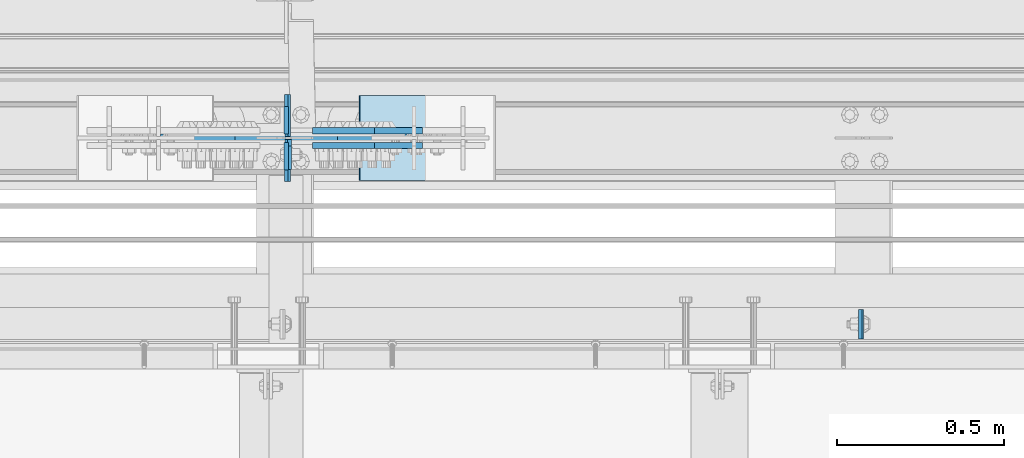
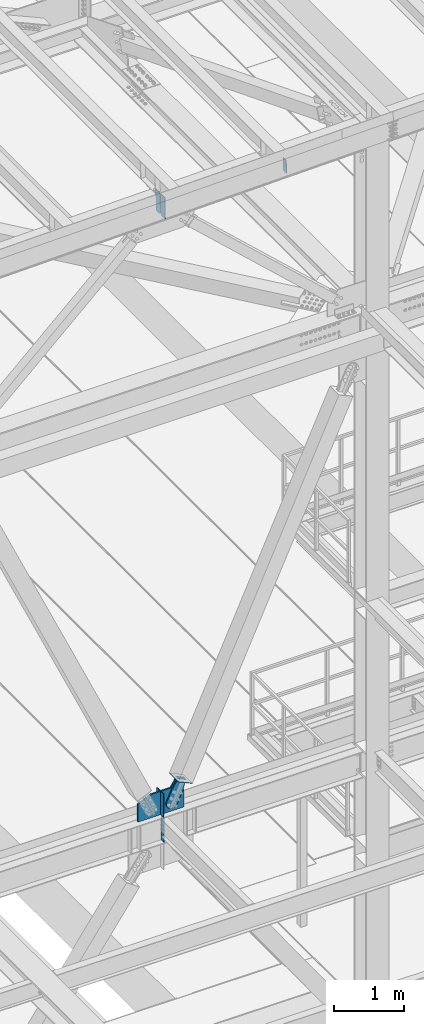
# One storey, part 3130 of 3843: 10 plates, 6 elements without a shape of their own.
"""IFC2X3 building model written with IfcOpenShell, lengths in millimetres."""

import ifcopenshell
import ifcopenshell.guid

model = None  # the IFC model being written
_history = None  # IfcOwnerHistory: only IFC2X3 demands one
_inside = {}  # id of a spatial element -> (the spatial element, [elements in it])
_under = {}  # id of a project, library or spatial element -> (it, [spatial elements below it])
_declared = {}  # id of a project -> (the project, [libraries it declares])
_typed = {}  # id of a type object -> (the type object, [elements of that type])
_made_of = {}  # id of a material, layer set ... -> (it, [elements and type objects made of it])


def new_model(schema):
    """Start an empty IFC model of exactly this schema.

    Asked for "IFC4X3", IfcOpenShell would pick the latest addendum, in which some entities
    have other attributes; the version numbers below select the first issue.
    IFC2X3 requires an IfcOwnerHistory on every rooted entity: one is made here for all.
    """
    global model, _history
    if schema == "IFC4X3":
        model = ifcopenshell.file(schema_version=(4, 3, 0, 0))
    else:
        model = ifcopenshell.file(schema=schema)
    _inside.clear()
    _under.clear()
    _declared.clear()
    _typed.clear()
    _made_of.clear()
    _history = None
    if model.schema == "IFC2X3":
        org = make("IfcOrganization", Name="unknown")
        user = make(
            "IfcPersonAndOrganization",
            ThePerson=make("IfcPerson", FamilyName="unknown"),
            TheOrganization=org,
        )
        app = make(
            "IfcApplication",
            ApplicationDeveloper=org,
            Version="unknown",
            ApplicationFullName="unknown",
            ApplicationIdentifier="unknown",
        )
        _history = make(
            "IfcOwnerHistory",
            OwningUser=user,
            OwningApplication=app,
            ChangeAction="ADDED",
            CreationDate=0,
        )
    return model


def make(cls, **values):
    """One entity of the class cls with the attributes given. An attribute that is None is left unset."""
    return model.create_entity(
        cls, **{name: value for name, value in values.items() if value is not None}
    )


def rooted(cls, **values):
    """An entity with a GlobalId (a new one), such as an element, a storey or a relation."""
    return make(cls, GlobalId=ifcopenshell.guid.new(), OwnerHistory=_history, **values)


def si_unit(unit_type, name, prefix=None):
    """IfcSIUnit, for example si_unit("LENGTHUNIT", "METRE", prefix="MILLI")."""
    return make("IfcSIUnit", UnitType=unit_type, Prefix=prefix, Name=name)


def assignment(units):
    """IfcUnitAssignment: the units of a project."""
    return None if units is None else make("IfcUnitAssignment", Units=units)


def point(xyz):
    """IfcCartesianPoint."""
    return None if xyz is None else make("IfcCartesianPoint", Coordinates=xyz)


def direction(xyz):
    """IfcDirection."""
    return None if xyz is None else make("IfcDirection", DirectionRatios=xyz)


def frame(location, z_axis=None, x_axis=None):
    """IfcAxis2Placement3D, a coordinate frame: its origin and axes. An axis left out is left unset."""
    return make(
        "IfcAxis2Placement3D",
        Location=point(location),
        Axis=direction(z_axis),
        RefDirection=direction(x_axis),
    )


def origin_with_axes():
    """The frame at (0, 0, 0) with the z axis (0, 0, 1) and the x axis (1, 0, 0) written out."""
    return frame((0.0, 0.0, 0.0), z_axis=(0.0, 0.0, 1.0), x_axis=(1.0, 0.0, 0.0))


def place(relative_to, where):
    """IfcLocalPlacement: puts the frame where relative to a parent placement (None: the world)."""
    return make(
        "IfcLocalPlacement", PlacementRelTo=relative_to, RelativePlacement=where
    )


def context(
    kind, dimensions, precision=None, world=None, true_north=None, identifier=None
):
    """IfcGeometricRepresentationContext, for example the 3D "Model" context."""
    return make(
        "IfcGeometricRepresentationContext",
        ContextIdentifier=identifier,
        ContextType=kind,
        CoordinateSpaceDimension=dimensions,
        Precision=precision,
        WorldCoordinateSystem=world,
        TrueNorth=true_north,
    )


def subcontext(parent, identifier, kind, view, scale=None):
    """IfcGeometricRepresentationSubContext, for example "Body" below "Model"."""
    return make(
        "IfcGeometricRepresentationSubContext",
        ContextIdentifier=identifier,
        ContextType=kind,
        ParentContext=parent,
        TargetScale=scale,
        TargetView=view,
    )


def project(units=None, contexts=None):
    """IfcProject with its units and contexts."""
    return rooted(
        "IfcProject",
        Name="project",
        RepresentationContexts=contexts,
        UnitsInContext=assignment(units),
    )


def spatial(cls, under=None, at=None, **own):
    """A site, building, storey or space (cls), placed at a placement, below another one or the project."""
    s = rooted(cls, ObjectPlacement=at, **own)
    if under is not None:
        _under.setdefault(under.id(), (under, []))[1].append(s)
    return s


def faces_of(points, faces, orient=None, outer=None):
    """IfcFace entities. A face is a list of loops; a loop is a list of indices into points, from 0.

    orient and outer hold one flag for each loop. By default every Orientation is true, the
    first loop of a face is its IfcFaceOuterBound and the others are IfcFaceBound.
    """
    made = []
    for i, loops in enumerate(faces):
        bounds = []
        for j, loop in enumerate(loops):
            is_outer = j == 0 if outer is None else outer[i][j]
            bounds.append(
                make(
                    "IfcFaceOuterBound" if is_outer else "IfcFaceBound",
                    Bound=make("IfcPolyLoop", Polygon=[points[k] for k in loop]),
                    Orientation=True if orient is None else orient[i][j],
                )
            )
        made.append(make("IfcFace", Bounds=bounds))
    return made


def faceted_brep(points, faces, orient=None, outer=None, voids=None):
    """IfcFacetedBrep: a solid bounded by flat faces; with voids (closed shells), ...WithVoids."""
    shared = [point(p) for p in points]
    hull = make("IfcClosedShell", CfsFaces=faces_of(shared, faces, orient, outer))
    if voids is None:
        return make("IfcFacetedBrep", Outer=hull)
    return make(
        "IfcFacetedBrepWithVoids",
        Outer=hull,
        Voids=[
            make(cls, CfsFaces=faces_of(shared, fs, o, b)) for cls, fs, o, b in voids
        ],
    )


def shape(context_of_items, identifier, shape_type, items):
    """IfcShapeRepresentation: the items that make up one representation, for example the "Body"."""
    return make(
        "IfcShapeRepresentation",
        ContextOfItems=context_of_items,
        RepresentationIdentifier=identifier,
        RepresentationType=shape_type,
        Items=items,
    )


def material(Name=None, Category=None):
    """IfcMaterial."""
    return make("IfcMaterial", Name=Name, Category=Category)


def made_of(thing, what):
    """Note that an element or type object is made of a material, layer set ...; save() writes the relation."""
    if what is not None:
        _made_of.setdefault(what.id(), (what, []))[1].append(thing)
    return thing


def type_object(cls, material=None, **own):
    """A type object (cls), such as IfcWallType, which elements share."""
    return made_of(rooted(cls, **own), material)


def element(
    cls,
    number,
    at=None,
    inside=None,
    cuts=None,
    type_object=None,
    material=None,
    context=None,
    identifier="Body",
    shape_type=None,
    held_by="IfcProductDefinitionShape",
    body=None,
    shapes=None,
    **own,
):
    """One element of the class cls, such as IfcWall. Its Tag is "e" and its number.

    at: its placement. inside: the storey or other place that contains it. cuts: it is an
    opening in that element (IfcRelVoidsElement). A single representation is given by context,
    identifier, shape_type and body (its items); several are given by shapes. held_by: the class
    of the entity that holds the representations. save() writes the other relations.
    """
    e = rooted(cls, Tag="e%d" % number, ObjectPlacement=at, **own)
    if body is not None:
        shapes = [shape(context, identifier, shape_type, body)]
    if shapes is not None:
        e.Representation = make(held_by, Representations=shapes)
    if inside is not None:
        _inside.setdefault(inside.id(), (inside, []))[1].append(e)
    if cuts is not None:
        rooted(
            "IfcRelVoidsElement", RelatingBuildingElement=cuts, RelatedOpeningElement=e
        )
    if type_object is not None:
        _typed.setdefault(type_object.id(), (type_object, []))[1].append(e)
    return made_of(e, material)


def aggregate(whole, parts):
    """IfcRelAggregates: a whole, such as a stair, and the parts it consists of."""
    return rooted("IfcRelAggregates", RelatingObject=whole, RelatedObjects=parts)


def save(model, path):
    """Write the relations noted so far, then the file.

    IfcRelAggregates (storeys below a building ...), IfcRelContainedInSpatialStructure (elements
    in a storey), IfcRelDefinesByType, IfcRelAssociatesMaterial and IfcRelDeclares: one each for
    every whole, place, type object, material and project.
    """
    for whole, parts in _under.values():
        aggregate(whole, parts)
    for where, things in _inside.values():
        rooted(
            "IfcRelContainedInSpatialStructure",
            RelatedElements=things,
            RelatingStructure=where,
        )
    for kind, things in _typed.values():
        rooted("IfcRelDefinesByType", RelatedObjects=things, RelatingType=kind)
    for what, things in _made_of.values():
        rooted("IfcRelAssociatesMaterial", RelatedObjects=things, RelatingMaterial=what)
    for by, libraries in _declared.values():
        rooted("IfcRelDeclares", RelatingContext=by, RelatedDefinitions=libraries)
    model.write(path)


model = new_model("IFC2X3")

# Units and contexts
model_context = context("Model", 3, precision=1e-05, world=origin_with_axes())
body_context = subcontext(model_context, "Body", "Model", "MODEL_VIEW")
ifc_project = project(units=[si_unit("LENGTHUNIT", "METRE", prefix="MILLI"), si_unit("AREAUNIT", "SQUARE_METRE"), si_unit("VOLUMEUNIT", "CUBIC_METRE"), si_unit("MASSUNIT", "GRAM", prefix="KILO"), si_unit("TIMEUNIT", "SECOND"), si_unit("PLANEANGLEUNIT", "RADIAN"), si_unit("SOLIDANGLEUNIT", "STERADIAN"), si_unit("THERMODYNAMICTEMPERATUREUNIT", "DEGREE_CELSIUS"), si_unit("LUMINOUSINTENSITYUNIT", "LUMEN")], contexts=[model_context])

# Site, building, storey
site_placement = place(None, origin_with_axes())
site = spatial("IfcSite", under=ifc_project, at=site_placement, CompositionType="ELEMENT")
building_placement = place(site_placement, origin_with_axes())
building = spatial("IfcBuilding", under=site, at=building_placement, Name="Undefined", CompositionType="ELEMENT")
storey_placement = place(building_placement, origin_with_axes())
storey = spatial("IfcBuildingStorey", under=building, at=storey_placement, Name="Undefined", CompositionType="ELEMENT", Elevation=0.0)

# Assembly, plate
assembly_1_placement = place(storey_placement, origin_with_axes())
assembly_1 = element("IfcElementAssembly", 1, at=assembly_1_placement, inside=storey, Name="BEAM", AssemblyPlace="NOTDEFINED", PredefinedType="RIGID_FRAME")
ifc_material_1 = material(Name="STEEL/A572-50")
plate_type_1 = type_object("IfcPlateType", PredefinedType="NOTDEFINED")
plate_1_placement = place(assembly_1_placement, frame((47249.338147201, 25014.2375588453, 45917.3307219245), z_axis=(1.23360001962283e-05, 0.999999999923877, 2.60990629612933e-07), x_axis=(0.0211520550054438, 0.0, -0.999776270257025)))
plate_1 = element("IfcPlate", 2, at=plate_1_placement, type_object=plate_type_1, material=ifc_material_1, Name="PLATE", context=body_context, shape_type="Brep", body=[
    faceted_brep([(0.0, -4.76249999999709, 0.0), (0.0, -4.76249999999709, 88.9000015258789), (0.0, 4.76249999999709, 88.9000015258789), (0.0, 4.76249999999709, 0.0), (228.600006102781, -4.7625000004191, 88.9000015257589), (228.600006102781, 4.76249999954598, 88.9000015257443), (228.600006103079, -4.7625000004482, 7.27595761418343e-12), (228.600006103079, 4.76249999954598, -7.27595761418343e-12)], [[[0, 1, 2, 3]], [[1, 4, 5, 2]], [[4, 6, 7, 5]], [[6, 0, 3, 7]], [[5, 7, 3, 2]], [[6, 4, 1, 0]]]),
])
aggregate(assembly_1, [plate_1])

# Assembly, plates
assembly_2_placement = place(storey_placement, origin_with_axes())
assembly_2 = element("IfcElementAssembly", 3, at=assembly_2_placement, inside=storey, Name="BEAM", AssemblyPlace="NOTDEFINED", PredefinedType="RIGID_FRAME")
plate_type_2 = type_object("IfcPlateType", PredefinedType="NOTDEFINED")
plate_2_placement = place(assembly_2_placement, frame((45537.8947387129, 25485.725, 45211.0164858346), z_axis=(-0.0211520980073474, 0.0, 0.999776269347241), x_axis=(0.0, 1.0, 0.0)))
plate_2 = element("IfcPlate", 4, at=plate_2_placement, type_object=plate_type_2, material=ifc_material_1, Name="STIFFENER", context=body_context, shape_type="Brep", body=[
    faceted_brep([(0.0, -4.76249999999709, 0.0), (0.0, -4.76249999999709, 377.824999997538), (0.0, 4.76249999999709, 377.824999997538), (0.0, 4.76249999999709, 0.0), (103.187499618536, -4.76249999999709, 377.824999997538), (103.187499618536, 4.76249999999709, 377.824999997538), (125.412500000006, -4.76249999999709, 355.599999616068), (125.412500000006, 4.76249999999709, 355.599999616068), (125.412500000006, -4.76249999999709, 22.2250003814697), (125.412500000006, 4.76249999999709, 22.2250003814697), (103.187499618536, -4.76249999999709, 0.0), (103.187499618536, 4.76249999999709, 0.0)], [[[0, 1, 2, 3]], [[1, 4, 5, 2]], [[4, 6, 7, 5]], [[6, 8, 9, 7]], [[8, 10, 11, 9]], [[10, 0, 3, 11]], [[5, 7, 9, 11, 3, 2]], [[10, 8, 6, 4, 1, 0]]]),
])
plate_3_placement = place(assembly_2_placement, frame((45537.8947387129, 25620.6625, 45211.0164858346), z_axis=(-0.0211520980073474, 0.0, 0.999776269347241), x_axis=(0.0, 1.0, 0.0)))
plate_3 = element("IfcPlate", 5, at=plate_3_placement, type_object=plate_type_2, material=ifc_material_1, Name="STIFFENER", context=body_context, shape_type="Brep", body=[
    faceted_brep([(0.0, -4.76249999999709, 22.2250003814697), (0.0, -4.76249999999709, 355.599999616068), (0.0, 4.76249999999709, 355.599999616068), (0.0, 4.76249999999709, 22.2250003814697), (22.2250003814697, -4.76249999999709, 377.824999997538), (22.2250003814697, 4.76249999999709, 377.824999997538), (125.412500000006, -4.76249999999709, 377.824999997538), (125.412500000006, 4.76249999999709, 377.824999997538), (125.412500000006, -4.76249999999709, 0.0), (125.412500000006, 4.76249999999709, 0.0), (22.2250003814697, -4.76249999999709, 0.0), (22.2250003814697, 4.76249999999709, 0.0)], [[[0, 1, 2, 3]], [[1, 4, 5, 2]], [[4, 6, 7, 5]], [[6, 8, 9, 7]], [[8, 10, 11, 9]], [[10, 0, 3, 11]], [[5, 7, 9, 11, 3, 2]], [[10, 8, 6, 4, 1, 0]]]),
])
aggregate(assembly_2, [plate_2, plate_3])

# Assembly, plate
assembly_3_placement = place(storey_placement, origin_with_axes())
assembly_3 = element("IfcElementAssembly", 6, at=assembly_3_placement, inside=storey, AssemblyPlace="NOTDEFINED", PredefinedType="RIGID_FRAME")
ifc_material_2 = material(Name="STEEL/A36")
plate_type_3 = type_object("IfcPlateType", PredefinedType="NOTDEFINED")
plate_4_placement = place(assembly_3_placement, frame((45909.4273293441, 25638.125, 35225.4522491175), z_axis=(-0.910112906153608, 0.0, 0.414360348069929), x_axis=(0.414360348069936, 0.0, 0.910112906153606)))
plate_4 = element("IfcPlate", 7, at=plate_4_placement, type_object=plate_type_3, material=ifc_material_2, context=body_context, shape_type="Brep", body=[
    faceted_brep([(0.0, -9.52500000000146, 0.0), (-101.599999999169, -9.52499999999418, -17.6403935107228), (-101.599999999169, 9.52499999999418, -17.6403935107228), (0.0, 9.52500000000146, 0.0), (-320.279297659972, -9.52499999999418, -17.640393512258), (-320.279297659972, 9.52499999999418, -17.640393512258), (-357.3374051259, -9.52499999999418, -10.2690776257878), (-357.3374051259, 9.52499999999418, -10.2690776257878), (-388.753751662653, -9.52499999999418, 10.7226540115298), (-388.753751662653, 9.52499999999418, 10.7226540115298), (-409.745483299826, -9.52499999999418, 42.1390005483918), (-409.745483299826, 9.52499999999418, 42.1390005483918), (-417.116799186137, -9.52499999999418, 79.1971049608474), (-417.116799186137, 9.52499999999418, 79.1971049608474), (-409.745483299252, -9.52499999999418, 116.255212426157), (-409.745483299252, 9.52499999999418, 116.255212426157), (-388.75375166202, -9.52499999999418, 147.671558962465), (-388.75375166202, 9.52499999999418, 147.671558962465), (-357.33740512564, -9.52499999999418, 168.663290599579), (-357.33740512564, 9.52499999999418, 168.663290599579), (-320.279299186061, -9.52499999999418, 176.034606486319), (-320.279299186061, 9.52499999999418, 176.034606486319), (-101.599999997048, -9.52499999999418, 176.034606487883), (-101.599999997048, 9.52499999999418, 176.034606487883), (1.71894498635083e-09, -9.52499999999418, 158.39421297863), (1.71894498635083e-09, 9.52499999999418, 158.39421297863), (69.8500000010408, -9.52499999999418, 158.394212979103), (69.8500000010408, 9.52499999999418, 158.394212979103), (69.8499999979995, -9.52499999999418, -4.00177668780088e-10), (69.8499999979995, 9.52499999999418, -4.00177668780088e-10)], [[[0, 1, 2, 3]], [[1, 4, 5, 2]], [[4, 6, 7, 5]], [[6, 8, 9, 7]], [[8, 10, 11, 9]], [[10, 12, 13, 11]], [[12, 14, 15, 13]], [[14, 16, 17, 15]], [[16, 18, 19, 17]], [[18, 20, 21, 19]], [[20, 22, 23, 21]], [[22, 24, 25, 23]], [[24, 26, 27, 25]], [[26, 28, 29, 27]], [[28, 0, 3, 29]], [[5, 7, 9, 11, 13, 15, 17, 19, 21, 23, 25, 27, 29, 3, 2]], [[28, 26, 24, 22, 20, 18, 16, 14, 12, 10, 8, 6, 4, 1, 0]]]),
])
aggregate(assembly_3, [plate_4])

assembly_4_placement = place(storey_placement, origin_with_axes())
assembly_4 = element("IfcElementAssembly", 8, at=assembly_4_placement, inside=storey, AssemblyPlace="NOTDEFINED", PredefinedType="RIGID_FRAME")
plate_5_placement = place(assembly_4_placement, frame((45909.4273293441, 25593.675, 35225.4522491175), z_axis=(-0.910112906153608, 0.0, 0.414360348069929), x_axis=(0.414360348069936, 0.0, 0.910112906153606)))
plate_5 = element("IfcPlate", 9, at=plate_5_placement, type_object=plate_type_3, material=ifc_material_2, context=body_context, shape_type="Brep", body=[
    faceted_brep([(0.0, -9.52500000000146, 0.0), (-101.599999999169, -9.52499999999418, -17.6403935107228), (-101.599999999169, 9.52499999999418, -17.6403935107228), (0.0, 9.52500000000146, 0.0), (-320.279297659972, -9.52499999999418, -17.640393512258), (-320.279297659972, 9.52499999999418, -17.640393512258), (-357.3374051259, -9.52499999999418, -10.2690776257878), (-357.3374051259, 9.52499999999418, -10.2690776257878), (-388.753751662653, -9.52499999999418, 10.7226540115298), (-388.753751662653, 9.52499999999418, 10.7226540115298), (-409.745483299826, -9.52499999999418, 42.1390005483918), (-409.745483299826, 9.52499999999418, 42.1390005483918), (-417.116799186137, -9.52499999999418, 79.1971049608474), (-417.116799186137, 9.52499999999418, 79.1971049608474), (-409.745483299252, -9.52499999999418, 116.255212426157), (-409.745483299252, 9.52499999999418, 116.255212426157), (-388.75375166202, -9.52499999999418, 147.671558962465), (-388.75375166202, 9.52499999999418, 147.671558962465), (-357.33740512564, -9.52499999999418, 168.663290599579), (-357.33740512564, 9.52499999999418, 168.663290599579), (-320.279299186061, -9.52499999999418, 176.034606486319), (-320.279299186061, 9.52499999999418, 176.034606486319), (-101.599999997048, -9.52499999999418, 176.034606487883), (-101.599999997048, 9.52499999999418, 176.034606487883), (1.71894498635083e-09, -9.52499999999418, 158.39421297863), (1.71894498635083e-09, 9.52499999999418, 158.39421297863), (69.8500000010408, -9.52499999999418, 158.394212979103), (69.8500000010408, 9.52499999999418, 158.394212979103), (69.8499999979995, -9.52499999999418, -4.00177668780088e-10), (69.8499999979995, 9.52499999999418, -4.00177668780088e-10)], [[[0, 1, 2, 3]], [[1, 4, 5, 2]], [[4, 6, 7, 5]], [[6, 8, 9, 7]], [[8, 10, 11, 9]], [[10, 12, 13, 11]], [[12, 14, 15, 13]], [[14, 16, 17, 15]], [[16, 18, 19, 17]], [[18, 20, 21, 19]], [[20, 22, 23, 21]], [[22, 24, 25, 23]], [[24, 26, 27, 25]], [[26, 28, 29, 27]], [[28, 0, 3, 29]], [[5, 7, 9, 11, 13, 15, 17, 19, 21, 23, 25, 27, 29, 3, 2]], [[28, 26, 24, 22, 20, 18, 16, 14, 12, 10, 8, 6, 4, 1, 0]]]),
])
aggregate(assembly_4, [plate_5])

assembly_5_placement = place(storey_placement, origin_with_axes())
assembly_5 = element("IfcElementAssembly", 10, at=assembly_5_placement, inside=storey, Name="Plate", AssemblyPlace="NOTDEFINED", PredefinedType="RIGID_FRAME")
plate_type_4 = type_object("IfcPlateType", PredefinedType="NOTDEFINED")
plate_6_placement = place(assembly_5_placement, frame((45980.5608357373, 25488.9, 35266.326403608), z_axis=(-0.910112906153608, 0.0, 0.414360348069929), x_axis=(0.0, 1.0, 0.0)))
plate_6 = element("IfcPlate", 11, at=plate_6_placement, type_object=plate_type_4, material=ifc_material_2, Name="Plate", context=body_context, shape_type="Brep", body=[
    faceted_brep([(0.0, -3.17499999999927, 0.0), (0.0, -3.17499999965185, 254.000000005151), (0.0, 3.17500000035216, 254.000000005166), (0.0, 3.17499999999927, 0.0), (254.0, -3.17499999965185, 254.000000005151), (254.0, 3.17500000035216, 254.000000005166), (254.0, -3.17500000000291, 0.0), (254.0, 3.17499999999927, 1.45519152283669e-11)], [[[0, 1, 2, 3]], [[1, 4, 5, 2]], [[4, 6, 7, 5]], [[6, 0, 3, 7]], [[5, 7, 3, 2]], [[6, 4, 1, 0]]]),
])
aggregate(assembly_5, [plate_6])

# Assembly, plates
assembly_6_placement = place(storey_placement, origin_with_axes())
assembly_6 = element("IfcElementAssembly", 12, at=assembly_6_placement, inside=storey, Name="BEAM", AssemblyPlace="NOTDEFINED", PredefinedType="RIGID_FRAME")
plate_type_5 = type_object("IfcPlateType", PredefinedType="NOTDEFINED")
plate_7_placement = place(assembly_6_placement, frame((45529.5, 25628.6, 34810.7), z_axis=(0.0, 1.0, 0.0), x_axis=(0.0, 0.0, 1.0)))
plate_7 = element("IfcPlate", 13, at=plate_7_placement, type_object=plate_type_5, material=ifc_material_1, Name="CB", context=body_context, shape_type="Brep", body=[
    faceted_brep([(0.0, -6.34999999999854, 19.0499992370605), (0.0, -6.34999999999854, 82.5499999999993), (0.0, 6.34999999999854, 82.5499999999993), (0.0, 6.34999999999854, 19.0499992370605), (405.932571589714, -6.34999999999854, 82.5499999999993), (405.932571589714, 6.34999999999854, 82.5499999999993), (405.932571589714, -6.34999999999854, 0.0), (405.932571589714, 6.34999999999854, 0.0), (19.0499992370605, -6.34999999999854, 0.0), (19.0499992370605, 6.34999999999854, 0.0)], [[[0, 1, 2, 3]], [[1, 4, 5, 2]], [[4, 6, 7, 5]], [[6, 8, 9, 7]], [[8, 0, 3, 9]], [[5, 7, 9, 3, 2]], [[8, 6, 4, 1, 0]]]),
])
plate_8_placement = place(assembly_6_placement, frame((45529.5, 25603.2, 34810.7), z_axis=(0.0, -1.0, 0.0), x_axis=(0.0, 0.0, 1.0)))
plate_8 = element("IfcPlate", 14, at=plate_8_placement, type_object=plate_type_5, material=ifc_material_1, Name="CB", context=body_context, shape_type="Brep", body=[
    faceted_brep([(0.0, -6.34999999999854, 19.0499992370605), (0.0, -6.34999999999854, 82.5499999999993), (0.0, 6.34999999999854, 82.5499999999993), (0.0, 6.34999999999854, 19.0499992370605), (405.932571589714, -6.34999999999854, 82.5499999999993), (405.932571589714, 6.34999999999854, 82.5499999999993), (405.932571589714, -6.34999999999854, 0.0), (405.932571589714, 6.34999999999854, 0.0), (19.0499992370605, -6.34999999999854, 0.0), (19.0499992370605, 6.34999999999854, 0.0)], [[[0, 1, 2, 3]], [[1, 4, 5, 2]], [[4, 6, 7, 5]], [[6, 8, 9, 7]], [[8, 0, 3, 9]], [[5, 7, 9, 3, 2]], [[8, 6, 4, 1, 0]]]),
])
plate_type_6 = type_object("IfcPlateType", PredefinedType="NOTDEFINED")
plate_9_placement = place(assembly_6_placement, frame((45153.1272849126, 25615.9, 34810.7), z_axis=(1.0, 0.0, 0.0), x_axis=(0.0, 0.0, 1.0)))
plate_9 = element("IfcPlate", 15, at=plate_9_placement, type_object=plate_type_6, material=ifc_material_1, Name="CB", context=body_context, shape_type="Brep", body=[
    faceted_brep([(0.0, -12.6999999999971, 0.0), (0.0, -12.7000000000007, 753.372650688019), (0.0, 12.7000000000007, 753.372650688019), (0.0, 12.6999999999971, 0.0), (304.450545417931, -12.7000000000007, 753.372650688019), (304.450545417931, 12.7000000000007, 753.372650688019), (405.932571589714, -12.7000000000007, 530.474629215241), (405.932571589714, 12.7000000000007, 530.474629215241), (405.932571589714, -12.7000000000007, 382.722715087417), (405.932571589714, 12.7000000000007, 382.722715087417), (405.932571589714, -12.7000000000007, 222.61884605074), (405.932571589714, 12.7000000000007, 222.61884605074), (304.893593922498, -12.7000000000007, 0.0), (304.893593922498, 12.7000000000007, 0.0)], [[[0, 1, 2, 3]], [[1, 4, 5, 2]], [[4, 6, 7, 5]], [[6, 8, 9, 7]], [[8, 10, 11, 9]], [[10, 12, 13, 11]], [[12, 0, 3, 13]], [[5, 7, 9, 11, 13, 3, 2]], [[12, 10, 8, 6, 4, 1, 0]]]),
])
plate_type_7 = type_object("IfcPlateType", PredefinedType="NOTDEFINED")
plate_10_placement = place(assembly_6_placement, frame((45539.0250000954, 25611.1375, 34369.375), z_axis=(0.0, 0.0, 1.0), x_axis=(0.0, -1.0, 0.0)))
plate_10 = element("IfcPlate", 16, at=plate_10_placement, type_object=plate_type_7, material=ifc_material_1, Name="PLATE", context=body_context, shape_type="Brep", body=[
    faceted_brep([(0.0, -6.34999999999854, 19.0499992370605), (0.0, -6.34999999999854, 406.400000762937), (0.0, 6.34999999999854, 406.400000762937), (0.0, 6.34999999999854, 19.0499992370605), (19.0499992370605, -6.34999999999854, 425.449999999997), (19.0499992370605, 6.34999999999854, 425.449999999997), (88.8999999999978, -6.34999999999854, 425.449999999997), (88.8999999999978, 6.34999999999854, 425.449999999997), (88.9000015258789, -6.34999999999854, 0.0), (88.9000015258789, 6.34999999999854, 0.0), (19.0499992370605, -6.34999999999854, 0.0), (19.0499992370605, 6.34999999999854, 0.0)], [[[0, 1, 2, 3]], [[1, 4, 5, 2]], [[4, 6, 7, 5]], [[6, 8, 9, 7]], [[8, 10, 11, 9]], [[10, 0, 3, 11]], [[5, 7, 9, 11, 3, 2]], [[10, 8, 6, 4, 1, 0]]]),
])
aggregate(assembly_6, [plate_7, plate_8, plate_9, plate_10])

save(model, "model.ifc")
